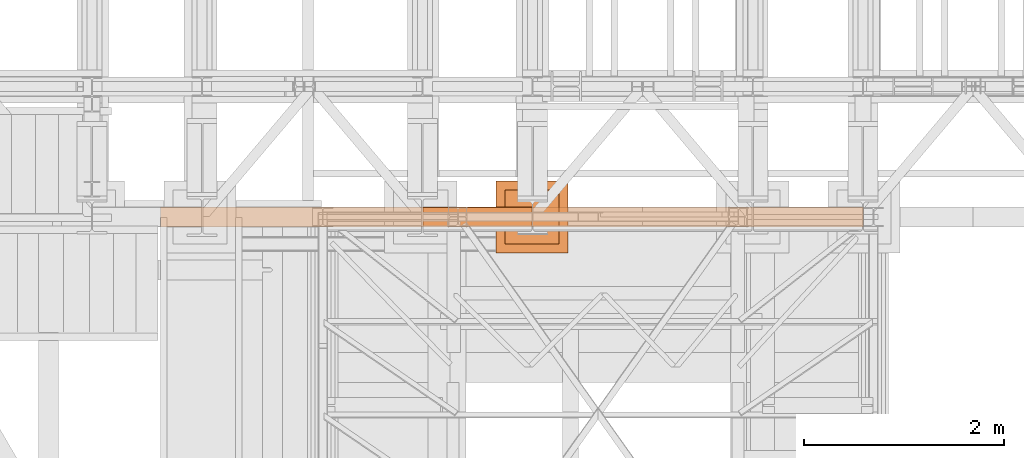
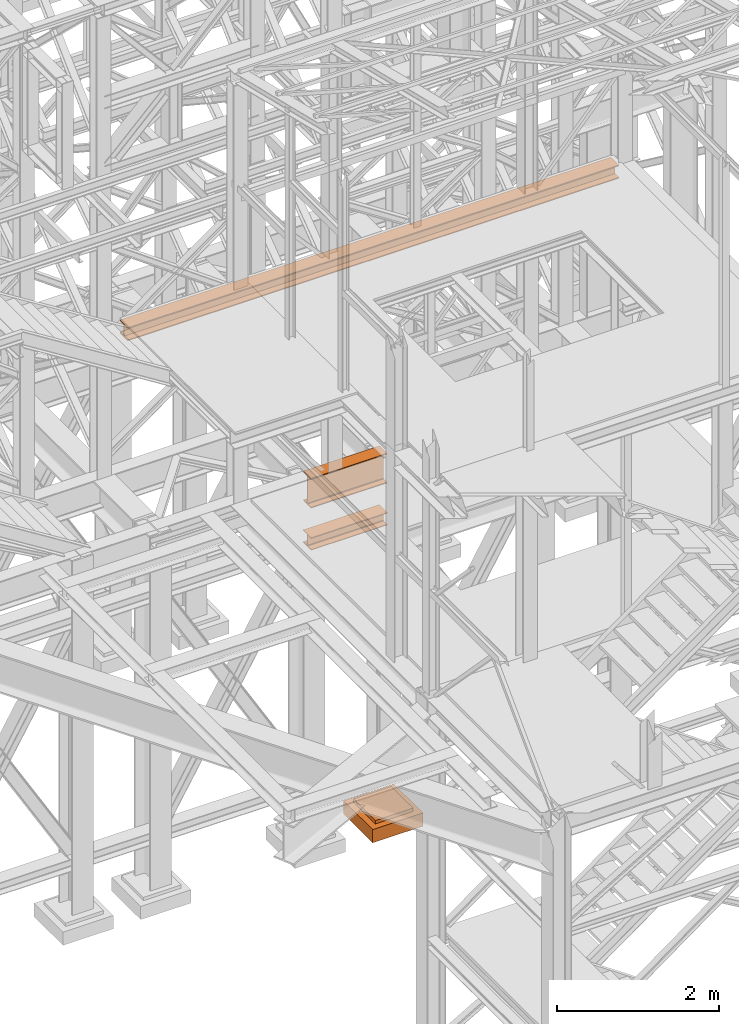
# One storey, part 39 of 208: 4 proxies.
"""IFC2X3 building model written with IfcOpenShell, lengths in millimetres."""

from ifc_helpers import new_model, entity, si_unit, converted_unit, frame, origin, origin_with_axes, place, context, subcontext, project, spatial, faceted_brep, element, save


model = new_model("IFC2X3")

# Units and contexts
model_context = context("Model", 3, precision=1e-05, world=origin())
plan_context = context("Plan", 3, precision=1e-05, world=origin())
body_context = subcontext(model_context, "Body", "Model", "MODEL_VIEW")
ifc_project = project(units=[si_unit("LENGTHUNIT", "METRE", prefix="MILLI"), converted_unit("PLANEANGLEUNIT", "DEGREE", entity("IfcPlaneAngleMeasure", 0.0174532925199433), si_unit("PLANEANGLEUNIT", "RADIAN"), dimensions=[0, 0, 0, 0, 0, 0, 0]), si_unit("AREAUNIT", "SQUARE_METRE"), si_unit("VOLUMEUNIT", "CUBIC_METRE")], contexts=[model_context, plan_context])

# Building, storey
building_placement = place(None, origin())
building = spatial("IfcBuilding", under=ifc_project, at=building_placement, CompositionType="COMPLEX")
storey_placement = place(building_placement, origin_with_axes())
storey = spatial("IfcBuildingStorey", under=building, at=storey_placement, Name="Geschoss", CompositionType="ELEMENT")

# Proxies
proxy_1_placement = place(storey_placement, frame((2200.00497459344, -17362.5323246858, 4202.989992847441), z_axis=(0.0, 0.0, 1.0), x_axis=(1.0, 0.0, 0.0)))
element("IfcBuildingElementProxy", 1, at=proxy_1_placement, inside=storey, context=body_context, shape_type="Brep", body=[
    faceted_brep([(1088.009999895692, 0.00999999999839929, 190.0100125169756), (1088.009999895692, 200.0100029802306, 190.0100125169756), (1088.009999895692, 200.0100029802306, 180.0100146031382), (1088.009999895692, 121.2600035762771, 180.0100071525576), (1088.009999895692, 111.9441915473326, 178.1454621052744), (1088.009999895692, 105.1245498640819, 171.3258190250399), (1088.009999895692, 103.2600015571697, 162.010007927418), (1088.009999895692, 103.2600015571697, 28.00999713897727), (1088.009999895692, 105.1245498640819, 18.69418604135535), (1088.009999895692, 111.9441915473326, 11.87454296112082), (1088.009999895692, 121.2600035762771, 10.00999791383765), (1088.009999895692, 200.0100029802306, 10.00999791383765), (1088.009999895692, 200.0100029802306, 0.01000000000021828), (1088.009999895692, 0.00999999999839929, 0.01000000000021828), (1088.009999895692, 0.00999999999839929, 10.00999791383765), (1088.009999895692, 78.75999940395195, 10.00999791383765), (1088.009999895692, 88.07581143289644, 11.87454296112082), (1088.009999895692, 94.89545311614711, 18.69418604135535), (1088.009999895692, 96.7600014230593, 28.00999713897727), (1088.009999895692, 96.7600014230593, 162.010007927418), (1088.009999895692, 94.89545311614711, 171.3258190250399), (1088.009999895692, 88.07581143289644, 178.1454621052744), (1088.009999895692, 78.75999940395195, 180.0100071525576), (1088.009999895692, 0.00999999999839929, 180.0100146031382), (1088.009999895692, 200.0100029802306, 190.0100125169756), (1088.009999895692, 0.00999999999839929, 190.0100125169756), (0.01000000000021828, 0.00999999999839929, 190.0100125169756), (0.01000000000021828, 200.0100029802306, 190.0100125169756), (1088.009999895692, 200.0100029802306, 180.0100146031382), (1088.009999895692, 200.0100029802306, 190.0100125169756), (0.01000000000021828, 200.0100029802306, 190.0100125169756), (0.01000000000021828, 200.0100029802306, 180.0100146031382), (1088.009999895692, 121.2600035762771, 180.0100071525576), (1088.009999895692, 200.0100029802306, 180.0100146031382), (0.01000000000021828, 200.0100029802306, 180.0100146031382), (0.01000000000021828, 121.2600035762771, 180.0100071525576), (1088.009999895692, 111.9441915473326, 178.1454621052744), (1088.009999895692, 121.2600035762771, 180.0100071525576), (0.01000000000021828, 121.2600035762771, 180.0100071525576), (0.01000000000021828, 111.9441915473326, 178.1454621052744), (1088.009999895692, 105.1245498640819, 171.3258190250399), (1088.009999895692, 111.9441915473326, 178.1454621052744), (0.01000000000021828, 111.9441915473326, 178.1454621052744), (0.01000000000021828, 105.1245498640819, 171.3258190250399), (1088.009999895692, 103.2600015571697, 162.010007927418), (1088.009999895692, 105.1245498640819, 171.3258190250399), (0.01000000000021828, 105.1245498640819, 171.3258190250399), (0.01000000000021828, 103.2600015571697, 162.010007927418), (1088.009999895692, 103.2600015571697, 28.00999713897727), (1088.009999895692, 103.2600015571697, 162.010007927418), (0.01000000000021828, 103.2600015571697, 162.010007927418), (0.01000000000021828, 103.2600015571697, 28.00999713897727), (1088.009999895692, 105.1245498640819, 18.69418604135535), (1088.009999895692, 103.2600015571697, 28.00999713897727), (0.01000000000021828, 103.2600015571697, 28.00999713897727), (0.01000000000021828, 105.1245498640819, 18.69418604135535), (1088.009999895692, 111.9441915473326, 11.87454296112082), (1088.009999895692, 105.1245498640819, 18.69418604135535), (0.01000000000021828, 105.1245498640819, 18.69418604135535), (0.01000000000021828, 111.9441915473326, 11.87454296112082), (1088.009999895692, 121.2600035762771, 10.00999791383765), (1088.009999895692, 111.9441915473326, 11.87454296112082), (0.01000000000021828, 111.9441915473326, 11.87454296112082), (0.01000000000021828, 121.2600035762771, 10.00999791383765), (1088.009999895692, 200.0100029802306, 10.00999791383765), (1088.009999895692, 121.2600035762771, 10.00999791383765), (0.01000000000021828, 121.2600035762771, 10.00999791383765), (0.01000000000021828, 200.0100029802306, 10.00999791383765), (1088.009999895692, 200.0100029802306, 0.01000000000021828), (1088.009999895692, 200.0100029802306, 10.00999791383765), (0.01000000000021828, 200.0100029802306, 10.00999791383765), (0.01000000000021828, 200.0100029802306, 0.01000000000021828), (1088.009999895692, 0.00999999999839929, 0.01000000000021828), (1088.009999895692, 200.0100029802306, 0.01000000000021828), (0.01000000000021828, 200.0100029802306, 0.01000000000021828), (0.01000000000021828, 0.00999999999839929, 0.01000000000021828), (1088.009999895692, 0.00999999999839929, 10.00999791383765), (1088.009999895692, 0.00999999999839929, 0.01000000000021828), (0.01000000000021828, 0.00999999999839929, 0.01000000000021828), (0.01000000000021828, 0.00999999999839929, 10.00999791383765), (1088.009999895692, 78.75999940395195, 10.00999791383765), (1088.009999895692, 0.00999999999839929, 10.00999791383765), (0.01000000000021828, 0.00999999999839929, 10.00999791383765), (0.01000000000021828, 78.75999940395195, 10.00999791383765), (1088.009999895692, 88.07581143289644, 11.87454296112082), (1088.009999895692, 78.75999940395195, 10.00999791383765), (0.01000000000021828, 78.75999940395195, 10.00999791383765), (0.01000000000021828, 88.07581143289644, 11.87454296112082), (1088.009999895692, 94.89545311614711, 18.69418604135535), (1088.009999895692, 88.07581143289644, 11.87454296112082), (0.01000000000021828, 88.07581143289644, 11.87454296112082), (0.01000000000021828, 94.89545311614711, 18.69418604135535), (1088.009999895692, 96.7600014230593, 28.00999713897727), (1088.009999895692, 94.89545311614711, 18.69418604135535), (0.01000000000021828, 94.89545311614711, 18.69418604135535), (0.01000000000021828, 96.7600014230593, 28.00999713897727), (1088.009999895692, 96.7600014230593, 162.010007927418), (1088.009999895692, 96.7600014230593, 28.00999713897727), (0.01000000000021828, 96.7600014230593, 28.00999713897727), (0.01000000000021828, 96.7600014230593, 162.010007927418), (1088.009999895692, 94.89545311614711, 171.3258190250399), (1088.009999895692, 96.7600014230593, 162.010007927418), (0.01000000000021828, 96.7600014230593, 162.010007927418), (0.01000000000021828, 94.89545311614711, 171.3258190250399), (1088.009999895692, 88.07581143289644, 178.1454621052744), (1088.009999895692, 94.89545311614711, 171.3258190250399), (0.01000000000021828, 94.89545311614711, 171.3258190250399), (0.01000000000021828, 88.07581143289644, 178.1454621052744), (1088.009999895692, 78.75999940395195, 180.0100071525576), (1088.009999895692, 88.07581143289644, 178.1454621052744), (0.01000000000021828, 88.07581143289644, 178.1454621052744), (0.01000000000021828, 78.75999940395195, 180.0100071525576), (1088.009999895692, 0.00999999999839929, 180.0100146031382), (1088.009999895692, 78.75999940395195, 180.0100071525576), (0.01000000000021828, 78.75999940395195, 180.0100071525576), (0.01000000000021828, 0.00999999999839929, 180.0100146031382), (1088.009999895692, 0.00999999999839929, 190.0100125169756), (1088.009999895692, 0.00999999999839929, 180.0100146031382), (0.01000000000021828, 0.00999999999839929, 180.0100146031382), (0.01000000000021828, 0.00999999999839929, 190.0100125169756), (0.01000000000021828, 0.00999999999839929, 190.0100125169756), (0.01000000000021828, 0.00999999999839929, 180.0100146031382), (0.01000000000021828, 78.75999940395195, 180.0100071525576), (0.01000000000021828, 88.07581143289644, 178.1454621052744), (0.01000000000021828, 94.89545311614711, 171.3258190250399), (0.01000000000021828, 96.7600014230593, 162.010007927418), (0.01000000000021828, 96.7600014230593, 28.00999713897727), (0.01000000000021828, 94.89545311614711, 18.69418604135535), (0.01000000000021828, 88.07581143289644, 11.87454296112082), (0.01000000000021828, 78.75999940395195, 10.00999791383765), (0.01000000000021828, 0.00999999999839929, 10.00999791383765), (0.01000000000021828, 0.00999999999839929, 0.01000000000021828), (0.01000000000021828, 200.0100029802306, 0.01000000000021828), (0.01000000000021828, 200.0100029802306, 10.00999791383765), (0.01000000000021828, 121.2600035762771, 10.00999791383765), (0.01000000000021828, 111.9441915473326, 11.87454296112082), (0.01000000000021828, 105.1245498640819, 18.69418604135535), (0.01000000000021828, 103.2600015571697, 28.00999713897727), (0.01000000000021828, 103.2600015571697, 162.010007927418), (0.01000000000021828, 105.1245498640819, 171.3258190250399), (0.01000000000021828, 111.9441915473326, 178.1454621052744), (0.01000000000021828, 121.2600035762771, 180.0100071525576), (0.01000000000021828, 200.0100029802306, 180.0100146031382), (0.01000000000021828, 200.0100029802306, 190.0100125169756)], [[[0, 1, 2, 3, 4, 5, 6, 7, 8, 9, 10, 11, 12, 13, 14, 15, 16, 17, 18, 19, 20, 21, 22, 23]], [[24, 25, 26, 27]], [[28, 29, 30, 31]], [[32, 33, 34, 35]], [[36, 37, 38, 39]], [[40, 41, 42, 43]], [[44, 45, 46, 47]], [[48, 49, 50, 51]], [[52, 53, 54, 55]], [[56, 57, 58, 59]], [[60, 61, 62, 63]], [[64, 65, 66, 67]], [[68, 69, 70, 71]], [[72, 73, 74, 75]], [[76, 77, 78, 79]], [[80, 81, 82, 83]], [[84, 85, 86, 87]], [[88, 89, 90, 91]], [[92, 93, 94, 95]], [[96, 97, 98, 99]], [[100, 101, 102, 103]], [[104, 105, 106, 107]], [[108, 109, 110, 111]], [[112, 113, 114, 115]], [[116, 117, 118, 119]], [[120, 121, 122, 123, 124, 125, 126, 127, 128, 129, 130, 131, 132, 133, 134, 135, 136, 137, 138, 139, 140, 141, 142, 143]]], orient=[[False], [False], [False], [False], [False], [False], [False], [False], [False], [False], [False], [False], [False], [False], [False], [False], [False], [False], [False], [False], [False], [False], [False], [False], [False], [False]]),
])
proxy_2_placement = place(storey_placement, frame((2199.254968580824, -17357.574399786, 4834.989987483023), z_axis=(0.0, 0.0, 1.0), x_axis=(1.0, 0.0, 0.0)))
element("IfcBuildingElementProxy", 2, at=proxy_2_placement, inside=storey, context=body_context, shape_type="Brep", body=[
    faceted_brep([(1088.009999895696, 0.00999999999839929, 450.0100178813937), (1088.009999895696, 190.0100125169738, 450.0100178813937), (1088.009999895696, 190.0100125169738, 435.4100240564349), (1088.009999895696, 120.7100073045476, 435.4100091552737), (1088.009999895696, 109.8415622657522, 433.2347078418734), (1088.009999895696, 101.8853126263603, 425.2784563398363), (1088.009999895696, 99.71000619068582, 414.4100113010409), (1088.009999895696, 99.71000619068582, 35.60999167919181), (1088.009999895696, 101.8853126263603, 24.74154664039634), (1088.009999895696, 109.8415622657522, 16.78529513835929), (1088.009999895696, 120.7100073045476, 14.60999382495902), (1088.009999895696, 190.0100125169738, 14.60999382495902), (1088.009999895696, 190.0100125169738, 0.01000000000021828), (1088.009999895696, 0.00999999999839929, 0.01000000000021828), (1088.009999895696, 0.00999999999839929, 14.60999382495902), (1088.009999895696, 69.31000521242458, 14.60999382495902), (1088.009999895696, 80.17845025122006, 16.78529513835929), (1088.009999895696, 88.13469989061196, 24.74154664039634), (1088.009999895696, 90.31000632628638, 35.60999167919181), (1088.009999895696, 90.31000632628638, 414.4100113010409), (1088.009999895696, 88.13469989061196, 425.2784563398363), (1088.009999895696, 80.17845025122006, 433.2347078418734), (1088.009999895696, 69.31000521242458, 435.4100091552737), (1088.009999895696, 0.00999999999839929, 435.4100240564349), (1088.009999895696, 190.0100125169738, 450.0100178813937), (1088.009999895696, 0.00999999999839929, 450.0100178813937), (0.01000000000021828, 0.00999999999839929, 450.0100178813937), (0.01000000000021828, 190.0100125169738, 450.0100178813937), (1088.009999895696, 190.0100125169738, 435.4100240564349), (1088.009999895696, 190.0100125169738, 450.0100178813937), (0.01000000000021828, 190.0100125169738, 450.0100178813937), (0.01000000000021828, 190.0100125169738, 435.4100240564349), (1088.009999895696, 120.7100073045476, 435.4100091552737), (1088.009999895696, 190.0100125169738, 435.4100240564349), (0.01000000000021828, 190.0100125169738, 435.4100240564349), (0.01000000000021828, 120.7100073045476, 435.4100091552737), (1088.009999895696, 109.8415622657522, 433.2347078418734), (1088.009999895696, 120.7100073045476, 435.4100091552737), (0.01000000000021828, 120.7100073045476, 435.4100091552737), (0.01000000000021828, 109.8415622657522, 433.2347078418734), (1088.009999895696, 101.8853126263603, 425.2784563398363), (1088.009999895696, 109.8415622657522, 433.2347078418734), (0.01000000000021828, 109.8415622657522, 433.2347078418734), (0.01000000000021828, 101.8853126263603, 425.2784563398363), (1088.009999895696, 99.71000619068582, 414.4100113010409), (1088.009999895696, 101.8853126263603, 425.2784563398363), (0.01000000000021828, 101.8853126263603, 425.2784563398363), (0.01000000000021828, 99.71000619068582, 414.4100113010409), (1088.009999895696, 99.71000619068582, 35.60999167919181), (1088.009999895696, 99.71000619068582, 414.4100113010409), (0.01000000000021828, 99.71000619068582, 414.4100113010409), (0.01000000000021828, 99.71000619068582, 35.60999167919181), (1088.009999895696, 101.8853126263603, 24.74154664039634), (1088.009999895696, 99.71000619068582, 35.60999167919181), (0.01000000000021828, 99.71000619068582, 35.60999167919181), (0.01000000000021828, 101.8853126263603, 24.74154664039634), (1088.009999895696, 109.8415622657522, 16.78529513835929), (1088.009999895696, 101.8853126263603, 24.74154664039634), (0.01000000000021828, 101.8853126263603, 24.74154664039634), (0.01000000000021828, 109.8415622657522, 16.78529513835929), (1088.009999895696, 120.7100073045476, 14.60999382495902), (1088.009999895696, 109.8415622657522, 16.78529513835929), (0.01000000000021828, 109.8415622657522, 16.78529513835929), (0.01000000000021828, 120.7100073045476, 14.60999382495902), (1088.009999895696, 190.0100125169738, 14.60999382495902), (1088.009999895696, 120.7100073045476, 14.60999382495902), (0.01000000000021828, 120.7100073045476, 14.60999382495902), (0.01000000000021828, 190.0100125169738, 14.60999382495902), (1088.009999895696, 190.0100125169738, 0.01000000000021828), (1088.009999895696, 190.0100125169738, 14.60999382495902), (0.01000000000021828, 190.0100125169738, 14.60999382495902), (0.01000000000021828, 190.0100125169738, 0.01000000000021828), (1088.009999895696, 0.00999999999839929, 0.01000000000021828), (1088.009999895696, 190.0100125169738, 0.01000000000021828), (0.01000000000021828, 190.0100125169738, 0.01000000000021828), (0.01000000000021828, 0.00999999999839929, 0.01000000000021828), (1088.009999895696, 0.00999999999839929, 14.60999382495902), (1088.009999895696, 0.00999999999839929, 0.01000000000021828), (0.01000000000021828, 0.00999999999839929, 0.01000000000021828), (0.01000000000021828, 0.00999999999839929, 14.60999382495902), (1088.009999895696, 69.31000521242458, 14.60999382495902), (1088.009999895696, 0.00999999999839929, 14.60999382495902), (0.01000000000021828, 0.00999999999839929, 14.60999382495902), (0.01000000000021828, 69.31000521242458, 14.60999382495902), (1088.009999895696, 80.17845025122006, 16.78529513835929), (1088.009999895696, 69.31000521242458, 14.60999382495902), (0.01000000000021828, 69.31000521242458, 14.60999382495902), (0.01000000000021828, 80.17845025122006, 16.78529513835929), (1088.009999895696, 88.13469989061196, 24.74154664039634), (1088.009999895696, 80.17845025122006, 16.78529513835929), (0.01000000000021828, 80.17845025122006, 16.78529513835929), (0.01000000000021828, 88.13469989061196, 24.74154664039634), (1088.009999895696, 90.31000632628638, 35.60999167919181), (1088.009999895696, 88.13469989061196, 24.74154664039634), (0.01000000000021828, 88.13469989061196, 24.74154664039634), (0.01000000000021828, 90.31000632628638, 35.60999167919181), (1088.009999895696, 90.31000632628638, 414.4100113010409), (1088.009999895696, 90.31000632628638, 35.60999167919181), (0.01000000000021828, 90.31000632628638, 35.60999167919181), (0.01000000000021828, 90.31000632628638, 414.4100113010409), (1088.009999895696, 88.13469989061196, 425.2784563398363), (1088.009999895696, 90.31000632628638, 414.4100113010409), (0.01000000000021828, 90.31000632628638, 414.4100113010409), (0.01000000000021828, 88.13469989061196, 425.2784563398363), (1088.009999895696, 80.17845025122006, 433.2347078418734), (1088.009999895696, 88.13469989061196, 425.2784563398363), (0.01000000000021828, 88.13469989061196, 425.2784563398363), (0.01000000000021828, 80.17845025122006, 433.2347078418734), (1088.009999895696, 69.31000521242458, 435.4100091552737), (1088.009999895696, 80.17845025122006, 433.2347078418734), (0.01000000000021828, 80.17845025122006, 433.2347078418734), (0.01000000000021828, 69.31000521242458, 435.4100091552737), (1088.009999895696, 0.00999999999839929, 435.4100240564349), (1088.009999895696, 69.31000521242458, 435.4100091552737), (0.01000000000021828, 69.31000521242458, 435.4100091552737), (0.01000000000021828, 0.00999999999839929, 435.4100240564349), (1088.009999895696, 0.00999999999839929, 450.0100178813937), (1088.009999895696, 0.00999999999839929, 435.4100240564349), (0.01000000000021828, 0.00999999999839929, 435.4100240564349), (0.01000000000021828, 0.00999999999839929, 450.0100178813937), (0.01000000000021828, 0.00999999999839929, 450.0100178813937), (0.01000000000021828, 0.00999999999839929, 435.4100240564349), (0.01000000000021828, 69.31000521242458, 435.4100091552737), (0.01000000000021828, 80.17845025122006, 433.2347078418734), (0.01000000000021828, 88.13469989061196, 425.2784563398363), (0.01000000000021828, 90.31000632628638, 414.4100113010409), (0.01000000000021828, 90.31000632628638, 35.60999167919181), (0.01000000000021828, 88.13469989061196, 24.74154664039634), (0.01000000000021828, 80.17845025122006, 16.78529513835929), (0.01000000000021828, 69.31000521242458, 14.60999382495902), (0.01000000000021828, 0.00999999999839929, 14.60999382495902), (0.01000000000021828, 0.00999999999839929, 0.01000000000021828), (0.01000000000021828, 190.0100125169738, 0.01000000000021828), (0.01000000000021828, 190.0100125169738, 14.60999382495902), (0.01000000000021828, 120.7100073045476, 14.60999382495902), (0.01000000000021828, 109.8415622657522, 16.78529513835929), (0.01000000000021828, 101.8853126263603, 24.74154664039634), (0.01000000000021828, 99.71000619068582, 35.60999167919181), (0.01000000000021828, 99.71000619068582, 414.4100113010409), (0.01000000000021828, 101.8853126263603, 425.2784563398363), (0.01000000000021828, 109.8415622657522, 433.2347078418734), (0.01000000000021828, 120.7100073045476, 435.4100091552737), (0.01000000000021828, 190.0100125169738, 435.4100240564349), (0.01000000000021828, 190.0100125169738, 450.0100178813937)], [[[0, 1, 2, 3, 4, 5, 6, 7, 8, 9, 10, 11, 12, 13, 14, 15, 16, 17, 18, 19, 20, 21, 22, 23]], [[24, 25, 26, 27]], [[28, 29, 30, 31]], [[32, 33, 34, 35]], [[36, 37, 38, 39]], [[40, 41, 42, 43]], [[44, 45, 46, 47]], [[48, 49, 50, 51]], [[52, 53, 54, 55]], [[56, 57, 58, 59]], [[60, 61, 62, 63]], [[64, 65, 66, 67]], [[68, 69, 70, 71]], [[72, 73, 74, 75]], [[76, 77, 78, 79]], [[80, 81, 82, 83]], [[84, 85, 86, 87]], [[88, 89, 90, 91]], [[92, 93, 94, 95]], [[96, 97, 98, 99]], [[100, 101, 102, 103]], [[104, 105, 106, 107]], [[108, 109, 110, 111]], [[112, 113, 114, 115]], [[116, 117, 118, 119]], [[120, 121, 122, 123, 124, 125, 126, 127, 128, 129, 130, 131, 132, 133, 134, 135, 136, 137, 138, 139, 140, 141, 142, 143]]], orient=[[False], [False], [False], [False], [False], [False], [False], [False], [False], [False], [False], [False], [False], [False], [False], [False], [False], [False], [False], [False], [False], [False], [False], [False], [False], [False]]),
])
proxy_3_placement = place(storey_placement, frame((2927.833884661118, -17622.57439531565, -315.01), z_axis=(0.0, 0.0, 1.0), x_axis=(1.0, 0.0, 0.0)))
element("IfcBuildingElementProxy", 3, at=proxy_3_placement, inside=storey, context=body_context, shape_type="Brep", body=[
    faceted_brep([(630.0100000000002, 630.0099999999984, 250.01), (630.0100000000002, 90.0099999999984, 250.01), (90.01000000000022, 90.0099999999984, 250.01), (90.01000000000022, 630.0099999999984, 250.01), (630.0100000000002, 630.0099999999984, 200.01), (630.0100000000002, 90.0099999999984, 200.01), (630.0100000000002, 90.0099999999984, 250.01), (630.0100000000002, 630.0099999999984, 250.01), (90.01000000000022, 630.0099999999984, 200.01), (630.0100000000002, 630.0099999999984, 200.01), (630.0100000000002, 630.0099999999984, 250.01), (90.01000000000022, 630.0099999999984, 250.01), (90.01000000000022, 90.0099999999984, 200.01), (90.01000000000022, 630.0099999999984, 200.01), (90.01000000000022, 630.0099999999984, 250.01), (90.01000000000022, 90.0099999999984, 250.01), (630.0100000000002, 90.0099999999984, 200.01), (90.01000000000022, 90.0099999999984, 200.01), (90.01000000000022, 90.0099999999984, 250.01), (630.0100000000002, 90.0099999999984, 250.01), (720.0100000000002, 0.00999999999839929, 0.009999999999990905), (720.0100000000002, 720.0099999999984, 0.009999999999990905), (0.01000000000021828, 720.0099999999984, 0.009999999999990905), (0.01000000000021828, 0.00999999999839929, 0.009999999999990905), (720.0100000000002, 720.0099999999984, 200.01), (720.0100000000002, 0.00999999999839929, 200.01), (0.01000000000021828, 0.00999999999839929, 200.01), (0.01000000000021828, 720.0099999999984, 200.01), (90.01000000000022, 90.0099999999984, 200.01), (630.0100000000002, 90.0099999999984, 200.01), (630.0100000000002, 630.0099999999984, 200.01), (90.01000000000022, 630.0099999999984, 200.01), (720.0100000000002, 720.0099999999984, 0.009999999999990905), (720.0100000000002, 0.00999999999839929, 0.009999999999990905), (720.0100000000002, 0.00999999999839929, 200.01), (720.0100000000002, 720.0099999999984, 200.01), (0.01000000000021828, 720.0099999999984, 0.009999999999990905), (720.0100000000002, 720.0099999999984, 0.009999999999990905), (720.0100000000002, 720.0099999999984, 200.01), (0.01000000000021828, 720.0099999999984, 200.01), (0.01000000000021828, 0.00999999999839929, 0.009999999999990905), (0.01000000000021828, 720.0099999999984, 0.009999999999990905), (0.01000000000021828, 720.0099999999984, 200.01), (0.01000000000021828, 0.00999999999839929, 200.01), (720.0100000000002, 0.00999999999839929, 0.009999999999990905), (0.01000000000021828, 0.00999999999839929, 0.009999999999990905), (0.01000000000021828, 0.00999999999839929, 200.01), (720.0100000000002, 0.00999999999839929, 200.01)], [[[0, 1, 2, 3]], [[4, 5, 6, 7]], [[8, 9, 10, 11]], [[12, 13, 14, 15]], [[16, 17, 18, 19]], [[20, 21, 22, 23]], [[24, 25, 26, 27], [28, 29, 30, 31]], [[32, 33, 34, 35]], [[36, 37, 38, 39]], [[40, 41, 42, 43]], [[44, 45, 46, 47]]], orient=[[False], [False], [False], [False], [False], [False], [False, False], [False], [False], [False], [False]]),
])
proxy_4_placement = place(storey_placement, frame((-421.7450362397049, -17362.57438536813, 8284.990002086157), z_axis=(0.0, 0.0, 1.0), x_axis=(1.0, 0.0, 0.0)))
element("IfcBuildingElementProxy", 4, at=proxy_4_placement, inside=storey, context=body_context, shape_type="Brep", body=[
    faceted_brep([(7020.010003278254, 0.00999999999839929, 0.01000000000021828), (0.01000000000021828, 0.00999999999839929, 0.01000000000021828), (0.01000000000021828, 0.00999999999839929, 15.01000000000022), (7020.010003278254, 0.00999999999839929, 15.01000000000022), (7020.010003278254, 0.00999999999839929, 15.01000000000022), (0.01000000000021828, 0.00999999999839929, 15.01000000000022), (0.01000000000021828, 95.5099999999984, 15.01000000000022), (7020.010003278254, 95.5099999999984, 15.01000000000022), (7020.010003278254, 95.5099999999984, 15.01000000000022), (0.01000000000021828, 95.5099999999984, 15.01000000000022), (0.01000000000021828, 95.5099999999984, 185.0100000000002), (7020.010003278254, 95.5099999999984, 185.0100000000002), (7020.010003278254, 95.5099999999984, 185.0100000000002), (0.01000000000021828, 95.5099999999984, 185.0100000000002), (0.01000000000021828, 0.00999999999839929, 185.0100000000002), (7020.010003278254, 0.00999999999839929, 185.0100000000002), (7020.010003278254, 0.00999999999839929, 185.0100000000002), (0.01000000000021828, 0.00999999999839929, 185.0100000000002), (0.01000000000021828, 0.00999999999839929, 200.0100000000002), (7020.010003278254, 0.00999999999839929, 200.0100000000002), (7020.010003278254, 0.00999999999839929, 200.0100000000002), (0.01000000000021828, 0.00999999999839929, 200.0100000000002), (0.01000000000021828, 200.0099999999984, 200.0100000000002), (7020.010003278254, 200.0099999999984, 200.0100000000002), (7020.010003278254, 200.0099999999984, 200.0100000000002), (0.01000000000021828, 200.0099999999984, 200.0100000000002), (0.01000000000021828, 200.0099999999984, 185.0100000000002), (7020.010003278254, 200.0099999999984, 185.0100000000002), (7020.010003278254, 200.0099999999984, 185.0100000000002), (0.01000000000021828, 200.0099999999984, 185.0100000000002), (0.01000000000021828, 104.5099999999984, 185.0100000000002), (7020.010003278254, 104.5099999999984, 185.0100000000002), (7020.010003278254, 104.5099999999984, 185.0100000000002), (0.01000000000021828, 104.5099999999984, 185.0100000000002), (0.01000000000021828, 104.5099999999984, 15.01000000000022), (7020.010003278254, 104.5099999999984, 15.01000000000022), (7020.010003278254, 104.5099999999984, 15.01000000000022), (0.01000000000021828, 104.5099999999984, 15.01000000000022), (0.01000000000021828, 200.0099999999984, 15.01000000000022), (7020.010003278254, 200.0099999999984, 15.01000000000022), (7020.010003278254, 200.0099999999984, 15.01000000000022), (0.01000000000021828, 200.0099999999984, 15.01000000000022), (0.01000000000021828, 200.0099999999984, 0.01000000000021828), (7020.010003278254, 200.0099999999984, 0.01000000000021828), (7020.010003278254, 200.0099999999984, 0.01000000000021828), (0.01000000000021828, 200.0099999999984, 0.01000000000021828), (0.01000000000021828, 0.00999999999839929, 0.01000000000021828), (7020.010003278254, 0.00999999999839929, 0.01000000000021828), (7020.010003278254, 0.00999999999839929, 0.01000000000021828), (7020.010003278254, 0.00999999999839929, 15.01000000000022), (7020.010003278254, 95.5099999999984, 15.01000000000022), (7020.010003278254, 95.5099999999984, 185.0100000000002), (7020.010003278254, 0.00999999999839929, 185.0100000000002), (7020.010003278254, 0.00999999999839929, 200.0100000000002), (7020.010003278254, 200.0099999999984, 200.0100000000002), (7020.010003278254, 200.0099999999984, 185.0100000000002), (7020.010003278254, 104.5099999999984, 185.0100000000002), (7020.010003278254, 104.5099999999984, 15.01000000000022), (7020.010003278254, 200.0099999999984, 15.01000000000022), (7020.010003278254, 200.0099999999984, 0.01000000000021828), (0.01000000000021828, 0.00999999999839929, 0.01000000000021828), (0.01000000000021828, 200.0099999999984, 0.01000000000021828), (0.01000000000021828, 200.0099999999984, 15.01000000000022), (0.01000000000021828, 104.5099999999984, 15.01000000000022), (0.01000000000021828, 104.5099999999984, 185.0100000000002), (0.01000000000021828, 200.0099999999984, 185.0100000000002), (0.01000000000021828, 200.0099999999984, 200.0100000000002), (0.01000000000021828, 0.00999999999839929, 200.0100000000002), (0.01000000000021828, 0.00999999999839929, 185.0100000000002), (0.01000000000021828, 95.5099999999984, 185.0100000000002), (0.01000000000021828, 95.5099999999984, 15.01000000000022), (0.01000000000021828, 0.00999999999839929, 15.01000000000022)], [[[0, 1, 2, 3]], [[4, 5, 6, 7]], [[8, 9, 10, 11]], [[12, 13, 14, 15]], [[16, 17, 18, 19]], [[20, 21, 22, 23]], [[24, 25, 26, 27]], [[28, 29, 30, 31]], [[32, 33, 34, 35]], [[36, 37, 38, 39]], [[40, 41, 42, 43]], [[44, 45, 46, 47]], [[48, 49, 50, 51, 52, 53, 54, 55, 56, 57, 58, 59]], [[60, 61, 62, 63, 64, 65, 66, 67, 68, 69, 70, 71]]], orient=[[False], [False], [False], [False], [False], [False], [False], [False], [False], [False], [False], [False], [False], [False]]),
])

save(model, "model.ifc")
